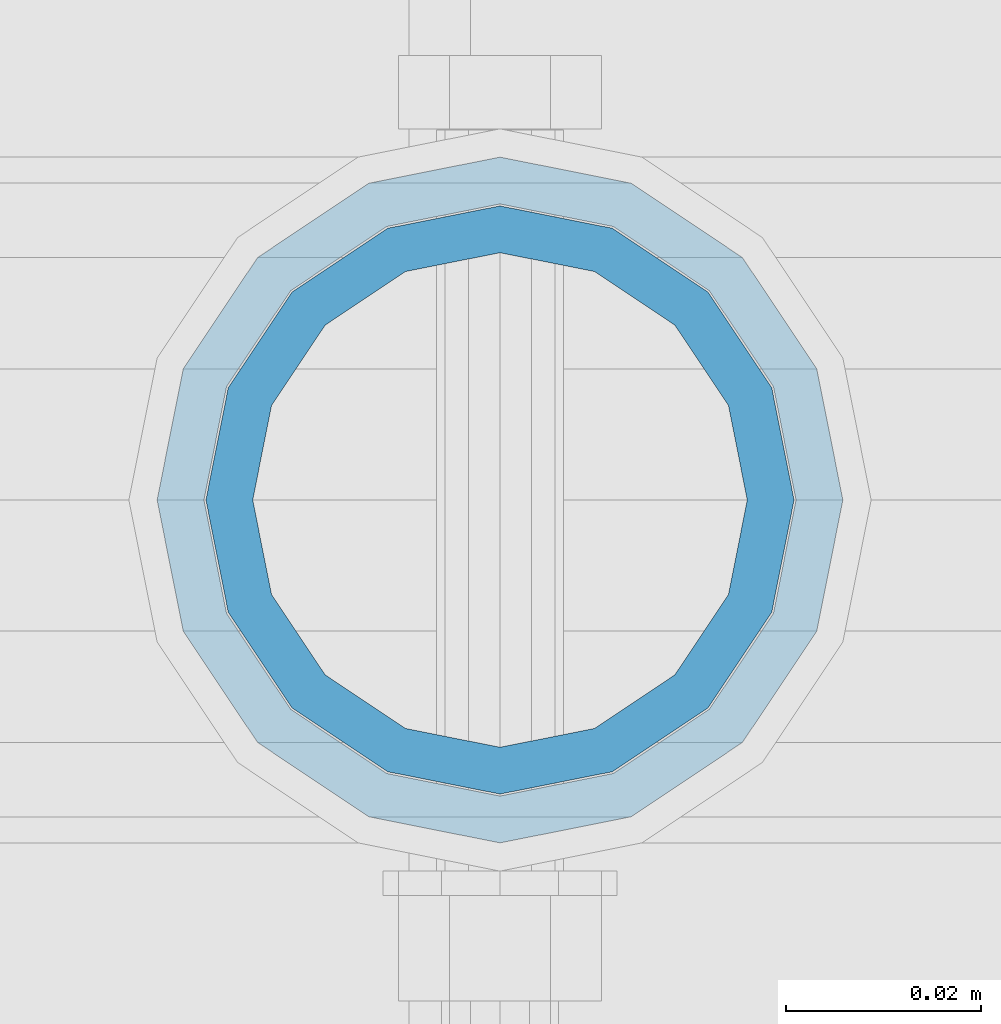
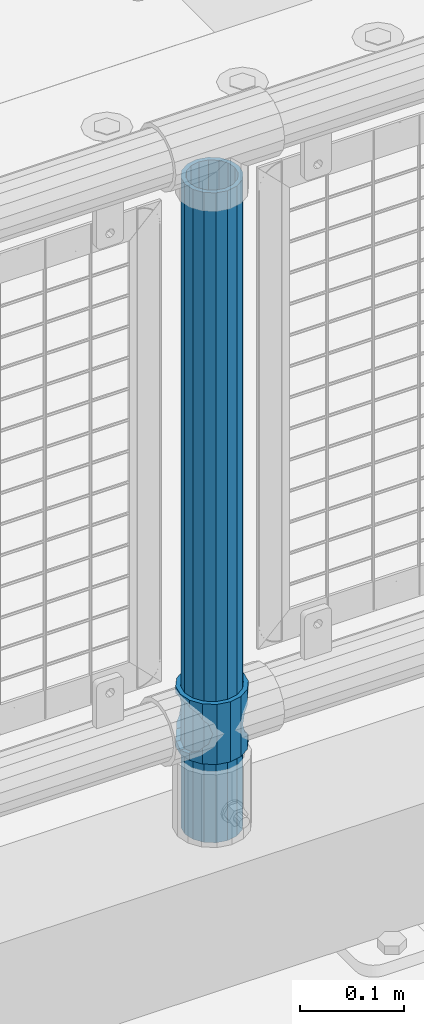
# One storey, part 76 of 242: 2 columns.
"""IFC2X3 building model written with IfcOpenShell, lengths in millimetres."""

from ifc_helpers import new_model, si_unit, frame, origin_with_axes, place, context, subcontext, project, spatial, faceted_brep, material, type_object, element, save


model = new_model("IFC2X3")

# Units and contexts
model_context = context("Model", 3, precision=1e-05, world=origin_with_axes())
body_context = subcontext(model_context, "Body", "Model", "MODEL_VIEW")
ifc_project = project(units=[si_unit("LENGTHUNIT", "METRE", prefix="MILLI"), si_unit("AREAUNIT", "SQUARE_METRE"), si_unit("VOLUMEUNIT", "CUBIC_METRE"), si_unit("MASSUNIT", "GRAM", prefix="KILO"), si_unit("TIMEUNIT", "SECOND"), si_unit("PLANEANGLEUNIT", "RADIAN"), si_unit("SOLIDANGLEUNIT", "STERADIAN"), si_unit("THERMODYNAMICTEMPERATUREUNIT", "DEGREE_CELSIUS"), si_unit("LUMINOUSINTENSITYUNIT", "LUMEN")], contexts=[model_context])

# Site, building, storey
site_placement = place(None, origin_with_axes())
site = spatial("IfcSite", under=ifc_project, at=site_placement, CompositionType="ELEMENT")
building_placement = place(site_placement, origin_with_axes())
building = spatial("IfcBuilding", under=site, at=building_placement, Name="Standard", CompositionType="ELEMENT")
storey_placement = place(building_placement, origin_with_axes())
storey = spatial("IfcBuildingStorey", under=building, at=storey_placement, Name="Undefined", CompositionType="ELEMENT", Elevation=0.0)

# Columns
ifc_material_1 = material()
column_type_1 = type_object("IfcColumnType", PredefinedType="NOTDEFINED")
column_1_placement = place(storey_placement, frame((-35297.0, -19335.5, 168.02), z_axis=(-1.0, 0.0, 0.0), x_axis=(0.0, 0.0, 1.0)))
element("IfcColumn", 1, at=column_1_placement, inside=storey, type_object=column_type_1, material=ifc_material_1, context=body_context, shape_type="Brep", body=[
    faceted_brep([(0.0, -25.3499999999985, 0.0), (0.0, -23.4203461491597, 9.70102501045403), (760.0, -23.4203461491597, 9.70102501045403), (760.0, -25.3499999999985, 0.0), (0.0, -17.9251569030785, 17.9251569030785), (760.0, -17.9251569030785, 17.9251569030785), (0.0, -9.70102501045403, 23.4203461491597), (760.0, -9.70102501045403, 23.4203461491597), (0.0, 0.0, 25.3499999999985), (760.0, 0.0, 25.3499999999985), (0.0, 9.70102501045403, 23.4203461491597), (760.0, 9.70102501045403, 23.4203461491597), (0.0, 17.9251569030785, 17.9251569030785), (760.0, 17.9251569030785, 17.9251569030785), (0.0, 23.4203461491597, 9.70102501045403), (760.0, 23.4203461491597, 9.70102501045403), (0.0, 25.3499999999985, 0.0), (760.0, 25.3499999999985, 0.0), (0.0, 23.4203461491597, -9.70102501045403), (760.0, 23.4203461491597, -9.70102501045403), (0.0, 17.9251569030785, -17.9251569030785), (760.0, 17.9251569030785, -17.9251569030785), (0.0, 9.70102501045403, -23.4203461491597), (760.0, 9.70102501045403, -23.4203461491597), (0.0, 0.0, -25.3499999999985), (760.0, 0.0, -25.3499999999985), (0.0, -9.70102501045403, -23.4203461491597), (760.0, -9.70102501045403, -23.4203461491597), (0.0, -17.9251569030785, -17.9251569030785), (760.0, -17.9251569030785, -17.9251569030785), (0.0, -23.4203461491597, -9.70102501045403), (760.0, -23.4203461491597, -9.70102501045403), (0.0, -30.1500000000015, 0.0), (0.0, -27.8549679052157, -11.5379054858058), (760.0, -27.8549679052157, -11.5379054858058), (760.0, -30.1500000000015, 0.0), (0.0, -21.3192694527752, -21.3192694527752), (760.0, -21.3192694527752, -21.3192694527752), (0.0, -11.5379054858058, -27.8549679052157), (760.0, -11.5379054858058, -27.8549679052157), (0.0, 0.0, -30.1500000000015), (760.0, 0.0, -30.1500000000015), (0.0, 11.5379054858058, -27.8549679052157), (760.0, 11.5379054858058, -27.8549679052157), (0.0, 21.3192694527752, -21.3192694527752), (760.0, 21.3192694527752, -21.3192694527752), (0.0, 27.8549679052157, -11.5379054858058), (760.0, 27.8549679052157, -11.5379054858058), (0.0, 30.1500000000015, 0.0), (760.0, 30.1500000000015, 0.0), (0.0, 27.8549679052157, 11.5379054858058), (760.0, 27.8549679052157, 11.5379054858058), (0.0, 21.3192694527752, 21.3192694527752), (760.0, 21.3192694527752, 21.3192694527752), (0.0, 11.5379054858058, 27.8549679052157), (760.0, 11.5379054858058, 27.8549679052157), (0.0, 0.0, 30.1500000000015), (760.0, 0.0, 30.1500000000015), (0.0, -11.5379054858058, 27.8549679052157), (760.0, -11.5379054858058, 27.8549679052157), (0.0, -21.3192694527752, 21.3192694527752), (760.0, -21.3192694527752, 21.3192694527752), (0.0, -27.8549679052157, 11.5379054858058), (760.0, -27.8549679052157, 11.5379054858058)], [[[0, 1, 2, 3]], [[1, 4, 5, 2]], [[4, 6, 7, 5]], [[6, 8, 9, 7]], [[8, 10, 11, 9]], [[10, 12, 13, 11]], [[12, 14, 15, 13]], [[14, 16, 17, 15]], [[16, 18, 19, 17]], [[18, 20, 21, 19]], [[20, 22, 23, 21]], [[22, 24, 25, 23]], [[24, 26, 27, 25]], [[26, 28, 29, 27]], [[28, 30, 31, 29]], [[30, 0, 3, 31]], [[32, 33, 34, 35]], [[33, 36, 37, 34]], [[36, 38, 39, 37]], [[38, 40, 41, 39]], [[40, 42, 43, 41]], [[42, 44, 45, 43]], [[44, 46, 47, 45]], [[46, 48, 49, 47]], [[48, 50, 51, 49]], [[50, 52, 53, 51]], [[52, 54, 55, 53]], [[54, 56, 57, 55]], [[56, 58, 59, 57]], [[58, 60, 61, 59]], [[60, 62, 63, 61]], [[62, 32, 35, 63]], [[37, 39, 41, 43, 45, 47, 49, 51, 53, 55, 57, 59, 61, 63, 35, 34], [5, 7, 9, 11, 13, 15, 17, 19, 21, 23, 25, 27, 29, 31, 3, 2]], [[62, 60, 58, 56, 54, 52, 50, 48, 46, 44, 42, 40, 38, 36, 33, 32], [30, 28, 26, 24, 22, 20, 18, 16, 14, 12, 10, 8, 6, 4, 1, 0]]]),
])
ifc_material_2 = material(Name="Misc_Undefined")
column_type_2 = type_object("IfcColumnType", PredefinedType="NOTDEFINED")
column_2_placement = place(storey_placement, frame((-35297.0, -19335.5, 263.02), z_axis=(-1.0, 0.0, 0.0), x_axis=(0.0, 0.0, 1.0)))
element("IfcColumn", 2, at=column_2_placement, inside=storey, type_object=column_type_2, material=ifc_material_2, context=body_context, shape_type="Brep", body=[
    faceted_brep([(63.1897438117172, 11.614442172282, -32.8397438117245), (63.1897438117172, 11.614442172282, -28.0397438117143), (56.6106908090114, 21.46069080901, -21.4606908090136), (56.6106908090114, 21.46069080901, -27.1226768591077), (61.9623795176744, 13.4513226476338, -32.4743655677739), (46.7644421722801, 28.0397438117179, -11.6144421722784), (46.7644421722801, 28.0397438117179, -20.0882031229849), (51.5310424080006, 24.8548033587067, -24.8548033587067), (35.1500000000015, 30.35, 0.0), (35.1499999999996, 30.3499999999985, -16.6306603983685), (23.5355578277192, 28.0397438117179, -11.6144421722784), (23.5355578277192, 28.0397438117179, -20.0882031229849), (18.7689575919987, 24.8548033587067, -24.8548033587067), (13.6893091909879, 21.46069080901, -21.4606908090136), (13.6893091909879, 21.46069080901, -27.1226768591077), (8.33762048232262, 13.4513226476338, -32.4743655677739), (7.11025618828211, 11.614442172282, -28.0397438117143), (7.11025618828211, 11.614442172282, -32.8397438117245), (4.79999999999961, 0.0, -30.3499999999985), (4.79999999999961, 0.0, -35.1500000000015), (7.11025618828211, -11.614442172282, -28.0397438117143), (7.11025618828211, -11.614442172282, -32.8397438117172), (13.6893091909879, -21.46069080901, -21.4606908090136), (13.6893091909879, -21.46069080901, -27.1226768591077), (8.33762048232484, -13.4513226476338, -32.4743655677739), (23.5355578277191, -28.0397438117179, -11.6144421722784), (23.5355578277191, -28.0397438117179, -20.0882031229921), (18.7689575919975, -24.8548033587067, -24.8548033587067), (35.1500000000015, -30.35, 0.0), (35.1499999999996, -30.3499999999985, -16.6306603983758), (46.7644421722801, -28.0397438117179, -11.6144421722784), (46.7644421722801, -28.0397438117179, -20.0882031229921), (51.5310424079973, -24.8548033587067, -24.8548033587067), (56.6106908090114, -21.46069080901, -21.4606908090136), (56.6106908090114, -21.46069080901, -27.1226768591077), (61.9623795176767, -13.4513226476338, -32.4743655677739), (63.1897438117172, -11.614442172282, -28.0397438117143), (63.1897438117172, -11.614442172282, -32.8397438117172), (65.4999999999997, 0.0, -30.3499999999985), (65.4999999999997, 0.0, -35.1500000000015), (0.0, -28.0397438117179, -11.6144421722784), (0.0, -30.3499999999985, 0.0), (0.0, -21.46069080901, -21.4606908090136), (0.0, -11.614442172282, -28.0397438117143), (0.0, 0.0, -30.3499999999985), (0.0, 11.614442172282, -28.0397438117143), (0.0, 21.46069080901, -21.4606908090136), (0.0, 28.0397438117179, -11.6144421722784), (0.0, 30.3499999999985, 0.0), (0.0, 28.0397438117179, 11.6144421722784), (23.5355578277192, 28.0397438117179, 11.614442172282), (0.0, 21.46069080901, 21.4606908090136), (13.6893091909879, 21.46069080901, 21.46069080901), (0.0, 11.614442172282, 28.0397438117143), (7.11025618828211, 11.614442172282, 28.0397438117179), (0.0, 0.0, 30.3499999999985), (4.79999999999961, 0.0, 30.3499999999985), (0.0, -11.614442172282, 28.0397438117143), (7.11025618828205, -11.614442172282, 28.0397438117179), (0.0, -21.46069080901, 21.4606908090136), (13.6893091909879, -21.46069080901, 21.46069080901), (0.0, -28.0397438117179, 11.6144421722784), (23.5355578277191, -28.0397438117179, 11.614442172282), (0.0, -32.4743655677703, 13.4513226476338), (0.0, -35.1500000000015, 0.0), (70.2999999999993, -35.1500000000015, 0.0), (70.2999999999993, -32.4743655677703, 13.4513226476338), (0.0, 13.4513226476338, -32.4743655677739), (0.0, 24.8548033587067, -24.8548033587067), (0.0, 0.0, -35.1500000000015), (0.0, -13.4513226476338, -32.4743655677739), (0.0, -24.8548033587067, -24.8548033587067), (0.0, -24.8548033587067, 24.8548033587067), (0.0, -13.4513226476338, 32.4743655677739), (0.0, 0.0, 35.1500000000015), (0.0, 13.4513226476338, 32.4743655677739), (0.0, 24.8548033587067, 24.8548033587067), (0.0, 32.4743655677703, 13.4513226476338), (0.0, 35.1500000000015, 0.0), (0.0, 32.4743655677703, -13.4513226476338), (0.0, -32.4743655677703, -13.4513226476338), (70.2999999999993, 32.4743655677703, 13.4513226476338), (70.2999999999993, 35.1500000000015, 0.0), (70.2999999999993, 32.4743655677703, -13.4513226476338), (70.2999999999993, 24.8548033587067, -24.8548033587067), (70.2999999999993, 13.4513226476338, -32.4743655677739), (70.2999999999993, 0.0, -35.1500000000015), (70.2999999999993, -13.4513226476338, -32.4743655677739), (70.2999999999993, -24.8548033587067, -24.8548033587067), (70.2999999999993, -32.4743655677703, -13.4513226476338), (70.2999999999993, 28.0397438117179, 11.6144421722784), (70.2999999999993, 21.46069080901, 21.4606908090136), (56.6106908090114, 21.46069080901, 21.46069080901), (46.7644421722801, 28.0397438117179, 11.614442172282), (70.2999999999993, 11.614442172282, 28.0397438117143), (63.1897438117172, 11.614442172282, 28.0397438117179), (70.2999999999993, 0.0, 30.3499999999985), (65.4999999999997, 0.0, 30.3499999999985), (70.2999999999993, -11.614442172282, 28.0397438117143), (63.1897438117172, -11.614442172282, 28.0397438117179), (70.2999999999993, -21.46069080901, 21.4606908090136), (56.6106908090114, -21.46069080901, 21.46069080901), (70.2999999999993, -28.0397438117179, 11.6144421722784), (46.7644421722801, -28.0397438117179, 11.614442172282), (70.2999999999993, -11.614442172282, -28.0397438117143), (70.2999999999993, 0.0, -30.3499999999985), (70.2999999999993, -21.46069080901, -21.4606908090136), (70.2999999999993, -28.0397438117179, -11.6144421722784), (70.2999999999993, -30.3499999999985, 0.0), (70.2999999999993, 24.8548033587067, 24.8548033587067), (70.2999999999993, 13.4513226476338, 32.4743655677739), (70.2999999999993, 0.0, 35.1500000000015), (70.2999999999993, -13.4513226476338, 32.4743655677739), (70.2999999999993, -24.8548033587067, 24.8548033587067), (70.2999999999993, 30.3499999999985, 0.0), (70.2999999999993, 28.0397438117179, -11.6144421722784), (70.2999999999993, 21.46069080901, -21.4606908090136), (70.2999999999993, 11.614442172282, -28.0397438117143), (61.9623795176744, 13.4513226476338, 32.4743655677703), (51.5310424080006, 24.8548033587067, 24.8548033587067), (56.6106908090114, 21.46069080901, 27.1226768591077), (65.4999999999997, 0.0, 35.1500000000015), (63.1897438117172, 11.614442172282, 32.8397438117136), (63.1897438117172, -11.614442172282, 32.8397438117172), (61.9623795176767, -13.4513226476338, 32.4743655677703), (56.6106908090114, -21.46069080901, 27.1226768591077), (51.5310424080038, -24.8548033587067, 24.8548033587067), (18.7689575919954, -24.8548033587067, 24.8548033587067), (46.7644421722801, -28.0397438117179, 20.0882031229885), (35.1499999999996, -30.3499999999985, 16.6306603983685), (23.5355578277191, -28.0397438117179, 20.0882031229885), (8.33762048232484, -13.4513226476338, 32.4743655677703), (13.6893091909879, -21.46069080901, 27.1226768591077), (4.79999999999961, 0.0, 35.1500000000015), (7.11025618828205, -11.614442172282, 32.8397438117172), (7.11025618828211, 11.614442172282, 32.8397438117136), (8.33762048232262, 13.4513226476338, 32.4743655677703), (13.6893091909879, 21.46069080901, 27.1226768591077), (18.768957592002, 24.8548033587067, 24.8548033587067), (23.5355578277192, 28.0397438117179, 20.0882031229812), (35.1499999999996, 30.3499999999985, 16.6306603983721), (46.7644421722801, 28.0397438117179, 20.0882031229812)], [[[0, 1, 2, 3, 4]], [[3, 2, 5, 6, 7]], [[6, 5, 8, 9]], [[9, 8, 10, 11]], [[12, 11, 10, 13, 14]], [[15, 14, 13, 16, 17]], [[17, 16, 18, 19]], [[19, 18, 20, 21]], [[21, 20, 22, 23, 24]], [[23, 22, 25, 26, 27]], [[26, 25, 28, 29]], [[29, 28, 30, 31]], [[32, 31, 30, 33, 34]], [[35, 34, 33, 36, 37]], [[37, 36, 38, 39]], [[39, 38, 1, 0]], [[40, 41, 28, 25]], [[42, 40, 25, 22]], [[43, 42, 22, 20]], [[44, 43, 20, 18]], [[45, 44, 18, 16]], [[46, 45, 16, 13]], [[47, 46, 13, 10]], [[48, 47, 10, 8]], [[49, 48, 8, 50]], [[51, 49, 50, 52]], [[53, 51, 52, 54]], [[55, 53, 54, 56]], [[57, 55, 56, 58]], [[59, 57, 58, 60]], [[61, 59, 60, 62]], [[41, 61, 62, 28]], [[63, 64, 65, 66]], [[67, 68, 12, 14, 15]], [[69, 67, 15, 17, 19]], [[24, 70, 69, 19, 21]], [[27, 71, 70, 24, 23]], [[63, 72, 73, 74, 75, 76, 77, 78, 79, 68, 67, 69, 70, 71, 80, 64], [40, 42, 43, 44, 45, 46, 47, 48, 49, 51, 53, 55, 57, 59, 61, 41]], [[78, 77, 81, 82]], [[79, 78, 82, 83]], [[68, 79, 83, 84, 7, 6, 9, 11, 12]], [[7, 84, 85, 4, 3]], [[4, 85, 86, 39, 0]], [[87, 88, 32, 34, 35]], [[86, 87, 35, 37, 39]], [[29, 31, 32, 88, 89, 80, 71, 27, 26]], [[64, 80, 89, 65]], [[90, 91, 92, 93]], [[91, 94, 95, 92]], [[94, 96, 97, 95]], [[96, 98, 99, 97]], [[98, 100, 101, 99]], [[100, 102, 103, 101]], [[104, 105, 38, 36]], [[106, 104, 36, 33]], [[107, 106, 33, 30]], [[108, 107, 30, 28]], [[102, 108, 28, 103]], [[88, 87, 86, 85, 84, 83, 82, 81, 109, 110, 111, 112, 113, 66, 65, 89], [100, 98, 96, 94, 91, 90, 114, 115, 116, 117, 105, 104, 106, 107, 108, 102]], [[118, 110, 109, 119, 120]], [[121, 111, 110, 118, 122]], [[112, 111, 121, 123, 124]], [[113, 112, 124, 125, 126]], [[127, 72, 63, 66, 113, 126, 128, 129, 130]], [[131, 73, 72, 127, 132]], [[133, 74, 73, 131, 134]], [[75, 74, 133, 135, 136]], [[76, 75, 136, 137, 138]], [[119, 109, 81, 77, 76, 138, 139, 140, 141]], [[92, 120, 119, 141, 93]], [[95, 122, 118, 120, 92]], [[97, 121, 122, 95]], [[99, 123, 121, 97]], [[101, 125, 124, 123, 99]], [[103, 128, 126, 125, 101]], [[28, 129, 128, 103]], [[62, 130, 129, 28]], [[60, 132, 127, 130, 62]], [[58, 134, 131, 132, 60]], [[56, 133, 134, 58]], [[54, 135, 133, 56]], [[52, 137, 136, 135, 54]], [[50, 139, 138, 137, 52]], [[8, 140, 139, 50]], [[93, 141, 140, 8]], [[114, 90, 93, 8]], [[115, 114, 8, 5]], [[116, 115, 5, 2]], [[117, 116, 2, 1]], [[105, 117, 1, 38]]]),
])

save(model, "model.ifc")
